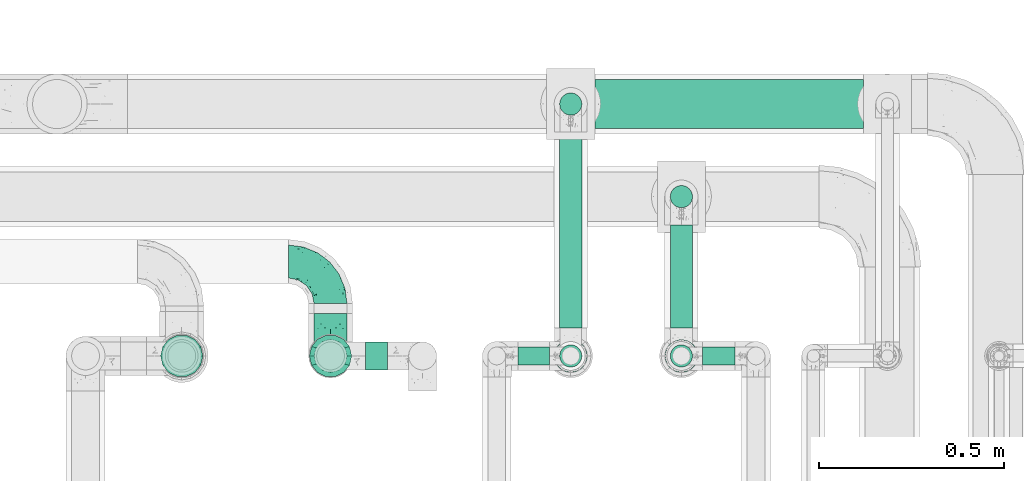
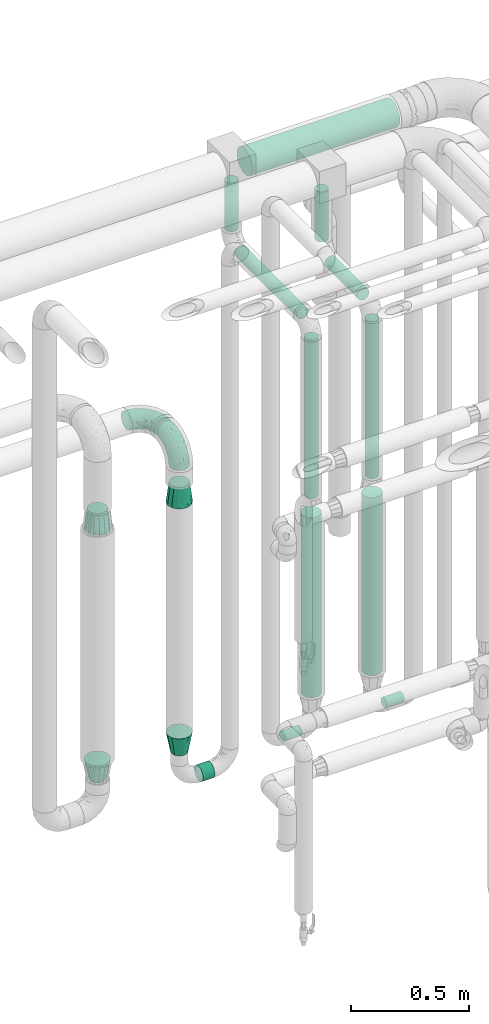
# One storey, part 712 of 827: 12 flow segments, 6 flow fittings.
"""IFC2X3 building model written with IfcOpenShell, lengths in millimetres."""

from ifc_helpers import new_model, entity, si_unit, converted_unit, derived_unit, direction, frame, origin, origin_2d_with_axis, place, context, subcontext, project, spatial, circle, extrude, faceted_brep, source, transform, mapped, material, type_object, type_shapes, element, save


model = new_model("IFC2X3")

# Units and contexts
model_context = context("Model", 3, precision=0.01, world=origin(), true_north=direction((6.12303176911189e-17, 1.0)))
body_context = subcontext(model_context, "Body", "Model", "MODEL_VIEW")
ifc_project = project(units=[si_unit("LENGTHUNIT", "METRE", prefix="MILLI"), si_unit("AREAUNIT", "SQUARE_METRE"), si_unit("VOLUMEUNIT", "CUBIC_METRE"), converted_unit("PLANEANGLEUNIT", "DEGREE", entity("IfcRatioMeasure", 0.0174532925199433), si_unit("PLANEANGLEUNIT", "RADIAN"), dimensions=[0, 0, 0, 0, 0, 0, 0]), si_unit("MASSUNIT", "GRAM", prefix="KILO"), derived_unit("MASSDENSITYUNIT", [(si_unit("MASSUNIT", "GRAM", prefix="KILO"), 1), (si_unit("LENGTHUNIT", "METRE"), -3)]), derived_unit("MOMENTOFINERTIAUNIT", [(si_unit("LENGTHUNIT", "METRE"), 4)]), si_unit("TIMEUNIT", "SECOND"), si_unit("FREQUENCYUNIT", "HERTZ"), si_unit("THERMODYNAMICTEMPERATUREUNIT", "DEGREE_CELSIUS"), derived_unit("THERMALTRANSMITTANCEUNIT", [(si_unit("MASSUNIT", "GRAM", prefix="KILO"), 1), (si_unit("THERMODYNAMICTEMPERATUREUNIT", "KELVIN"), -1), (si_unit("TIMEUNIT", "SECOND"), -3)]), derived_unit("VOLUMETRICFLOWRATEUNIT", [(si_unit("LENGTHUNIT", "METRE"), 3), (si_unit("TIMEUNIT", "SECOND"), -1)]), derived_unit("MASSFLOWRATEUNIT", [(si_unit("MASSUNIT", "GRAM", prefix="KILO"), 1), (si_unit("TIMEUNIT", "SECOND"), -1)]), derived_unit("ROTATIONALFREQUENCYUNIT", [(si_unit("TIMEUNIT", "SECOND"), -1)]), si_unit("ELECTRICCURRENTUNIT", "AMPERE"), si_unit("ELECTRICVOLTAGEUNIT", "VOLT"), si_unit("POWERUNIT", "WATT"), si_unit("FORCEUNIT", "NEWTON", prefix="KILO"), si_unit("ILLUMINANCEUNIT", "LUX"), si_unit("LUMINOUSFLUXUNIT", "LUMEN"), si_unit("LUMINOUSINTENSITYUNIT", "CANDELA"), derived_unit("USERDEFINED", [(si_unit("MASSUNIT", "GRAM", prefix="KILO"), -1), (si_unit("LENGTHUNIT", "METRE"), -2), (si_unit("TIMEUNIT", "SECOND"), 3), (si_unit("LUMINOUSFLUXUNIT", "LUMEN"), 1)]), derived_unit("LINEARVELOCITYUNIT", [(si_unit("LENGTHUNIT", "METRE"), 1), (si_unit("TIMEUNIT", "SECOND"), -1)]), si_unit("PRESSUREUNIT", "PASCAL"), derived_unit("USERDEFINED", [(si_unit("LENGTHUNIT", "METRE"), -2), (si_unit("MASSUNIT", "GRAM", prefix="KILO"), 1), (si_unit("TIMEUNIT", "SECOND"), -2)]), derived_unit("LINEARFORCEUNIT", [(si_unit("MASSUNIT", "GRAM", prefix="KILO"), 1), (si_unit("LENGTHUNIT", "METRE"), 1), (si_unit("TIMEUNIT", "SECOND"), -2), (si_unit("LENGTHUNIT", "METRE"), -1)]), derived_unit("PLANARFORCEUNIT", [(si_unit("MASSUNIT", "GRAM", prefix="KILO"), 1), (si_unit("LENGTHUNIT", "METRE"), 1), (si_unit("TIMEUNIT", "SECOND"), -2), (si_unit("LENGTHUNIT", "METRE"), -2)])], contexts=[model_context])

# Site, building, storey
site_placement = place(None, origin())
site = spatial("IfcSite", under=ifc_project, at=site_placement, CompositionType="ELEMENT")
building_placement = place(site_placement, origin())
building = spatial("IfcBuilding", under=site, at=building_placement, CompositionType="ELEMENT")
storey_placement = place(building_placement, frame((0.0, 0.0, 28200.0)))
storey = spatial("IfcBuildingStorey", under=building, at=storey_placement, Name="08", CompositionType="ELEMENT", Elevation=28200.0)

# Flow segments
pipe_segment_type_1 = type_object("IfcPipeSegmentType", PredefinedType="NOTDEFINED")
flow_segment_1_placement = place(storey_placement, frame((59362.89, 18112.0, 2831.9)))
element("IfcFlowSegment", 1, at=flow_segment_1_placement, inside=storey, type_object=pipe_segment_type_1, context=body_context, shape_type="SweptSolid", body=[
    extrude(circle(Radius=66.5, at=origin_2d_with_axis()), frame((0.0, 68.1, 68.1), z_axis=(1.0, 0.0, 0.0), x_axis=(0.0, 1.0, 0.0)), (0.0, 0.0, 1.0), 725.240640582081),
])
pipe_segment_type_2 = type_object("IfcPipeSegmentType", PredefinedType="NOTDEFINED")
flow_segment_2_placement = place(storey_placement, frame((59266.3, 18148.5, 2577.24)))
element("IfcFlowSegment", 2, at=flow_segment_2_placement, inside=storey, type_object=pipe_segment_type_2, context=body_context, shape_type="SweptSolid", body=[
    extrude(circle(Radius=30.0, at=origin_2d_with_axis()), frame((31.6, 31.6, 0.0)), (0.0, 0.0, 1.0), 252.756811194297),
])
flow_segment_3_placement = place(storey_placement, frame((59266.3, 17575.0, 2470.65)))
element("IfcFlowSegment", 3, at=flow_segment_3_placement, inside=storey, type_object=pipe_segment_type_2, context=body_context, shape_type="SweptSolid", body=[
    extrude(circle(Radius=30.0, at=origin_2d_with_axis()), frame((31.6, 0.0, 31.6), z_axis=(0.0, 1.0, 0.0), x_axis=(-1.0, 0.0, 0.0)), (0.0, 0.0, 1.0), 530.096114108994),
])
flow_segment_4_placement = place(storey_placement, frame((59266.3, 17468.4, 1602.24)))
element("IfcFlowSegment", 4, at=flow_segment_4_placement, inside=storey, type_object=pipe_segment_type_2, context=body_context, shape_type="SweptSolid", body=[
    extrude(circle(Radius=30.0, at=origin_2d_with_axis()), frame((31.6, 31.6, 0.0)), (0.0, 0.0, 1.0), 825.000000000016),
])
flow_segment_5_placement = place(storey_placement, frame((59565.07, 17898.5, 2570.74)))
element("IfcFlowSegment", 5, at=flow_segment_5_placement, inside=storey, type_object=pipe_segment_type_2, context=body_context, shape_type="SweptSolid", body=[
    extrude(circle(Radius=30.0, at=origin_2d_with_axis()), frame((31.6, 31.6, 0.0)), (0.0, 0.0, 1.0), 259.256811194313),
])
flow_segment_6_placement = place(storey_placement, frame((59565.07, 17576.0, 2463.15)))
element("IfcFlowSegment", 6, at=flow_segment_6_placement, inside=storey, type_object=pipe_segment_type_2, context=body_context, shape_type="SweptSolid", body=[
    extrude(circle(Radius=30.0, at=origin_2d_with_axis()), frame((31.6, 0.0, 31.6), z_axis=(0.0, 1.0, 0.0), x_axis=(-1.0, 0.0, 0.0)), (0.0, 0.0, 1.0), 278.096097794324),
])
flow_segment_7_placement = place(storey_placement, frame((59565.07, 17468.4, 1602.24)))
element("IfcFlowSegment", 7, at=flow_segment_7_placement, inside=storey, type_object=pipe_segment_type_2, context=body_context, shape_type="SweptSolid", body=[
    extrude(circle(Radius=30.0, at=origin_2d_with_axis()), frame((31.6, 31.6, 0.0)), (0.0, 0.0, 1.0), 816.499999999996),
])
flow_segment_8_placement = place(storey_placement, frame((59155.13, 17474.4, 374.4)))
element("IfcFlowSegment", 8, at=flow_segment_8_placement, inside=storey, type_object=pipe_segment_type_2, context=body_context, shape_type="SweptSolid", body=[
    extrude(circle(Radius=24.0, at=origin_2d_with_axis()), frame((0.0, 25.6, 25.6), z_axis=(1.0, 0.0, 0.0), x_axis=(0.0, -1.0, 0.0)), (0.0, 0.0, 1.0), 86.0000000000064),
])
flow_segment_9_placement = place(storey_placement, frame((59653.67, 17474.4, 374.4)))
element("IfcFlowSegment", 9, at=flow_segment_9_placement, inside=storey, type_object=pipe_segment_type_2, context=body_context, shape_type="SweptSolid", body=[
    extrude(circle(Radius=24.0, at=origin_2d_with_axis()), frame((0.0, 25.6, 25.6), z_axis=(1.0, 0.0, 0.0), x_axis=(0.0, 1.0, 0.0)), (0.0, 0.0, 1.0), 87.4629414974364),
])
flow_segment_10_placement = place(storey_placement, frame((58744.38, 17460.65, 310.65)))
element("IfcFlowSegment", 10, at=flow_segment_10_placement, inside=storey, type_object=pipe_segment_type_2, context=body_context, shape_type="SweptSolid", body=[
    extrude(circle(Radius=37.75, at=origin_2d_with_axis()), frame((0.0, 39.35, 39.35), z_axis=(1.0, 0.0, 0.0), x_axis=(0.0, 1.0, 0.0)), (0.0, 0.0, 1.0), 58.5322202972613),
])
flow_segment_11_placement = place(storey_placement, frame((59550.82, 17454.15, 589.0)))
element("IfcFlowSegment", 11, at=flow_segment_11_placement, inside=storey, type_object=pipe_segment_type_2, context=body_context, shape_type="SweptSolid", body=[
    extrude(circle(Radius=44.25, at=origin_2d_with_axis()), frame((45.85, 45.85, 0.0)), (0.0, 0.0, 1.0), 924.243188805704),
])
flow_segment_12_placement = place(storey_placement, frame((59252.05, 17454.15, 579.0)))
element("IfcFlowSegment", 12, at=flow_segment_12_placement, inside=storey, type_object=pipe_segment_type_2, context=body_context, shape_type="SweptSolid", body=[
    extrude(circle(Radius=44.25, at=origin_2d_with_axis()), frame((45.85, 45.85, 0.0)), (0.0, 0.0, 1.0), 934.243188805697),
])

# Flow fittings
ifc_material = material()
pipe_fitting_type_1 = type_object("IfcPipeFittingType", Name="ADSK_1", PredefinedType="NOTDEFINED", material=ifc_material)
shared_shape_1 = source(origin(), body_context, "Body", "Brep", [
    faceted_brep([(-114.0, 22.22, -38.49), (-114.0, 11.5, -42.94), (-114.0, 0.0, -44.45), (-114.0, -11.5, -42.94), (-114.0, -22.23, -38.49), (-114.0, -31.43, -31.43), (-114.0, -38.49, -22.23), (-114.0, -42.94, -11.5), (-114.0, -44.45, 0.0), (-114.0, -42.94, 11.5), (-114.0, -38.49, 22.22), (-114.0, -31.43, 31.43), (-114.0, -22.23, 38.49), (-114.0, -11.5, 42.94), (-114.0, 0.0, 44.45), (-114.0, 11.5, 42.94), (-114.0, 22.22, 38.49), (-114.0, 31.43, 31.43), (-114.0, 38.49, 22.22), (-114.0, 42.94, 11.5), (-114.0, 44.45, 0.0), (-114.0, 42.94, -11.5), (-114.0, 38.49, -22.23), (-114.0, 31.43, -31.43), (0.0, 114.0, -44.45), (-11.5, 114.0, -42.94), (-22.22, 114.0, -38.49), (-31.43, 114.0, -31.43), (-38.49, 114.0, -22.23), (-42.94, 114.0, -11.5), (-44.45, 114.0, 0.0), (-42.94, 114.0, 11.5), (-38.49, 114.0, 22.22), (-31.43, 114.0, 31.43), (-22.22, 114.0, 38.49), (-11.5, 114.0, 42.94), (0.0, 114.0, 44.45), (11.5, 114.0, 42.94), (22.23, 114.0, 38.49), (31.43, 114.0, 31.43), (38.49, 114.0, 22.22), (42.94, 114.0, 11.5), (44.45, 114.0, 0.0), (42.94, 114.0, -11.5), (38.49, 114.0, -22.23), (31.43, 114.0, -31.43), (22.23, 114.0, -38.49), (11.5, 114.0, -42.94), (-24.5, -15.82, 8.24), (-7.18, -2.06, 7.97), (-13.53, -4.79, 15.72), (-92.03, -41.56, 0.0), (-77.08, -37.56, 14.57), (23.74, 74.96, 33.55), (-72.99, -39.05, 0.0), (-84.56, -15.6, 40.23), (-47.88, -6.37, 37.83), (-59.8, 2.77, 43.37), (-84.46, -33.54, 25.41), (16.69, 49.28, 31.02), (6.37, 47.88, 37.83), (3.35, 25.47, 29.77), (-47.43, 81.55, 19.51), (-74.96, -23.74, 33.55), (-46.77, -27.89, 11.23), (-53.88, -31.14, 0.0), (-87.05, 38.52, 28.81), (-63.44, 55.78, 24.79), (-93.24, 43.37, 18.58), (-16.67, 16.67, 37.64), (-25.47, -3.35, 29.77), (-17.2, 97.7, 41.53), (-7.42, 85.54, 44.3), (-67.09, 46.29, 31.23), (-18.08, 42.1, 44.06), (-32.93, 14.9, 42.17), (-11.54, 34.94, 41.69), (-95.7, 27.79, 36.14), (-88.55, -4.92, 43.79), (-2.77, 59.8, 43.37), (-87.65, 48.44, 9.87), (-81.01, 8.37, 44.32), (-37.63, 90.26, 28.6), (-51.29, 61.56, 30.59), (-29.32, 87.72, 36.52), (23.49, 49.5, 23.28), (8.19, 20.11, 19.18), (-70.06, 58.9, 9.01), (-87.38, 49.74, 0.0), (-88.15, 18.57, 41.8), (-7.96, 6.22, 24.33), (33.54, 84.46, 25.41), (37.56, 77.08, 14.57), (-58.37, 34.98, 40.92), (-62.38, 23.02, 43.45), (24.15, 39.93, 12.16), (31.14, 53.88, 0.0), (-58.13, 14.61, 44.45), (-37.17, 26.09, 44.37), (4.92, 88.55, 43.79), (-34.77, -23.22, 0.0), (-49.5, -23.49, 23.28), (41.56, 92.03, 0.0), (-57.83, 66.03, 19.12), (-71.84, 54.46, 17.06), (-46.46, 94.23, 8.51), (-49.74, 87.38, 0.0), (-38.96, 59.98, 38.88), (-55.29, 46.95, 36.83), (-64.82, 64.82, 0.0), (-55.88, 73.75, 10.01), (15.6, 84.56, 40.23), (-21.6, 76.38, 42.11), (-49.04, -15.53, 31.95), (-19.97, 55.59, 44.33), (-73.61, 33.95, 37.2), (-31.05, 58.14, 42.19), (-41.3, 41.3, 43.02), (-27.36, -11.22, 22.61), (9.28, 15.84, 8.73), (23.22, 34.77, 0.0), (39.05, 72.99, 0.0), (-1.96, 1.96, 0.0), (10.63, 18.37, 0.0), (-18.37, -10.63, 0.0), (-97.7, 17.2, -41.53), (9.28, 15.84, -8.73), (-13.53, -4.79, -15.72), (8.19, 20.11, -19.18), (-85.54, 7.42, -44.3), (-8.37, 81.01, -44.32), (-90.26, 37.63, -28.6), (-87.72, 29.32, -36.52), (-27.79, 95.7, -36.14), (-38.52, 87.05, -28.81), (-94.23, 46.46, -8.51), (-84.56, -15.6, -40.23), (-73.75, 55.88, -10.01), (-10.19, -4.86, -7.51), (-76.38, 21.6, -42.11), (-59.98, 38.96, -38.88), (-49.28, -16.69, -31.02), (-47.88, -6.37, -37.83), (-25.47, -3.35, -29.77), (-34.98, 58.37, -40.92), (-46.95, 55.29, -36.83), (-77.08, -37.56, -14.57), (-18.57, 88.15, -41.8), (-23.02, 62.38, -43.45), (-55.78, 63.44, -24.79), (-43.37, 93.24, -18.58), (-84.46, -33.54, -25.41), (-33.95, 73.61, -37.2), (-46.29, 67.09, -31.23), (-74.96, -23.74, -33.55), (-48.44, 87.65, -9.87), (-45.44, -27.06, -11.87), (-88.55, -4.92, -43.79), (-49.5, -23.49, -23.28), (-14.61, 58.13, -44.45), (-26.09, 37.17, -44.37), (15.6, 84.56, -40.23), (6.37, 47.88, -37.83), (-2.77, 59.8, -43.37), (-81.55, 47.43, -19.51), (33.54, 84.46, -25.41), (23.49, 49.5, -23.28), (23.74, 74.96, -33.55), (-42.1, 18.08, -44.06), (-14.9, 32.93, -42.17), (-34.94, 11.54, -41.69), (-61.56, 51.29, -30.59), (-27.36, -11.22, -22.61), (37.56, 77.08, -14.57), (4.92, 88.55, -43.79), (-59.8, 2.77, -43.37), (-66.03, 57.83, -19.12), (-54.46, 71.84, -17.06), (-55.59, 19.97, -44.33), (-58.9, 70.06, -9.01), (24.15, 39.93, -12.16), (15.53, 49.04, -31.95), (-58.14, 31.05, -42.19), (-41.3, 41.3, -43.02), (-16.67, 16.67, -37.64), (3.35, 25.47, -29.77), (-7.96, 6.22, -24.33), (-26.36, -16.33, -11.05)], [[[0, 1, 2, 3, 4, 5, 6, 7, 8, 9, 10, 11, 12, 13, 14, 15, 16, 17, 18, 19, 20, 21, 22, 23]], [[24, 25, 26, 27, 28, 29, 30, 31, 32, 33, 34, 35, 36, 37, 38, 39, 40, 41, 42, 43, 44, 45, 46, 47]], [[48, 49, 50]], [[51, 52, 9]], [[53, 39, 38]], [[9, 52, 10]], [[54, 52, 51]], [[55, 56, 57]], [[11, 10, 58]], [[59, 60, 61]], [[32, 31, 62]], [[63, 12, 11]], [[63, 55, 12]], [[64, 52, 65]], [[66, 67, 68]], [[69, 56, 70]], [[35, 71, 72]], [[67, 66, 73]], [[74, 75, 76]], [[16, 77, 17]], [[13, 78, 14]], [[76, 79, 74]], [[68, 80, 19]], [[18, 17, 66]], [[14, 78, 81]], [[20, 19, 80]], [[82, 83, 84]], [[85, 61, 86]], [[87, 88, 80]], [[18, 68, 19]], [[15, 89, 16]], [[14, 81, 15]], [[70, 90, 61]], [[17, 77, 66]], [[91, 85, 92]], [[93, 89, 94]], [[95, 96, 92]], [[84, 71, 34]], [[94, 97, 98]], [[37, 36, 99]], [[40, 39, 91]], [[40, 92, 41]], [[65, 100, 64]], [[91, 92, 40]], [[58, 101, 63]], [[92, 102, 41]], [[92, 85, 95]], [[67, 103, 104]], [[34, 33, 84]], [[105, 62, 31]], [[52, 58, 10]], [[106, 105, 30]], [[93, 107, 108]], [[106, 109, 110]], [[53, 111, 60]], [[84, 112, 71]], [[84, 107, 112]], [[33, 82, 84]], [[12, 55, 13]], [[113, 56, 63]], [[111, 38, 37]], [[34, 71, 35]], [[36, 35, 72]], [[112, 114, 72]], [[110, 105, 106]], [[111, 53, 38]], [[115, 108, 73]], [[89, 15, 81]], [[104, 87, 80]], [[110, 87, 103]], [[33, 32, 82]], [[116, 107, 117]], [[112, 116, 114]], [[99, 72, 79]], [[56, 55, 63]], [[78, 55, 57]], [[101, 118, 113]], [[56, 69, 75]], [[99, 111, 37]], [[79, 76, 60]], [[79, 60, 111]], [[60, 69, 61]], [[101, 58, 52]], [[63, 11, 58]], [[39, 53, 91]], [[85, 91, 53]], [[94, 89, 81]], [[77, 89, 115]], [[84, 83, 107]], [[93, 108, 115]], [[98, 114, 117]], [[79, 72, 114]], [[98, 117, 94]], [[98, 57, 75]], [[32, 62, 82]], [[83, 82, 62]], [[70, 113, 118]], [[61, 85, 59]], [[48, 64, 100]], [[95, 119, 120]], [[69, 70, 61]], [[70, 118, 90]], [[72, 99, 36]], [[111, 99, 79]], [[55, 78, 13]], [[81, 78, 57]], [[94, 81, 97]], [[93, 94, 117]], [[66, 68, 18]], [[80, 68, 104]], [[103, 87, 104]], [[80, 88, 20]], [[50, 49, 119]], [[95, 85, 86]], [[119, 95, 86]], [[121, 92, 96]], [[50, 119, 86]], [[119, 122, 123, 120]], [[110, 109, 87]], [[88, 87, 109]], [[62, 105, 110]], [[30, 105, 31]], [[81, 57, 97]], [[57, 98, 97]], [[107, 93, 117]], [[89, 93, 115]], [[107, 83, 108]], [[73, 108, 83]], [[67, 73, 83]], [[115, 73, 66]], [[103, 83, 62]], [[67, 104, 68]], [[83, 103, 67]], [[110, 103, 62]], [[89, 77, 16]], [[66, 77, 115]], [[56, 75, 57]], [[76, 75, 69]], [[60, 76, 69]], [[79, 114, 74]], [[114, 98, 74]], [[75, 74, 98]], [[9, 8, 51]], [[102, 92, 121]], [[102, 42, 41]], [[72, 71, 112]], [[52, 54, 65]], [[64, 48, 118]], [[101, 52, 64]], [[124, 122, 49]], [[118, 48, 50]], [[49, 48, 124]], [[119, 49, 122]], [[48, 100, 124]], [[114, 116, 117]], [[112, 107, 116]], [[101, 113, 63]], [[70, 56, 113]], [[64, 118, 101]], [[90, 50, 86]], [[50, 90, 118]], [[61, 90, 86]], [[85, 53, 59]], [[60, 59, 53]], [[95, 120, 96]], [[125, 1, 0]], [[126, 127, 128]], [[2, 1, 129]], [[24, 130, 25]], [[131, 132, 23]], [[27, 133, 134]], [[88, 135, 20]], [[136, 4, 3]], [[88, 109, 137]], [[138, 122, 124]], [[139, 132, 140]], [[141, 142, 143]], [[144, 140, 145]], [[125, 132, 139]], [[6, 146, 7]], [[144, 147, 148]], [[146, 51, 7]], [[134, 149, 150]], [[146, 6, 151]], [[152, 145, 153]], [[154, 4, 136]], [[154, 136, 142]], [[150, 155, 29]], [[43, 42, 102]], [[65, 146, 156]], [[0, 23, 132]], [[157, 3, 2]], [[146, 151, 158]], [[148, 159, 160]], [[161, 162, 163]], [[135, 164, 21]], [[165, 166, 167]], [[168, 169, 170]], [[147, 25, 130]], [[171, 132, 131]], [[155, 30, 29]], [[172, 141, 143]], [[134, 28, 27]], [[149, 134, 153]], [[173, 165, 44]], [[26, 25, 147]], [[22, 21, 164]], [[24, 174, 130]], [[133, 27, 26]], [[170, 175, 168]], [[24, 47, 174]], [[45, 167, 46]], [[28, 150, 29]], [[1, 125, 129]], [[156, 100, 65]], [[165, 45, 44]], [[161, 46, 167]], [[173, 44, 43]], [[6, 5, 151]], [[173, 102, 121]], [[137, 135, 88]], [[46, 161, 47]], [[102, 173, 43]], [[149, 176, 177]], [[172, 158, 141]], [[139, 178, 129]], [[154, 5, 4]], [[156, 146, 158]], [[106, 155, 179]], [[173, 96, 180]], [[181, 162, 167]], [[177, 179, 155]], [[137, 179, 176]], [[23, 22, 131]], [[182, 140, 183]], [[139, 182, 178]], [[157, 129, 175]], [[157, 136, 3]], [[175, 170, 142]], [[175, 142, 136]], [[142, 184, 143]], [[162, 161, 167]], [[174, 161, 163]], [[181, 166, 185]], [[162, 184, 169]], [[5, 154, 151]], [[158, 151, 154]], [[166, 165, 173]], [[167, 45, 165]], [[148, 147, 130]], [[133, 147, 152]], [[132, 171, 140]], [[144, 145, 152]], [[160, 178, 183]], [[175, 129, 178]], [[160, 183, 148]], [[160, 163, 169]], [[22, 164, 131]], [[171, 131, 164]], [[162, 185, 184]], [[186, 127, 172]], [[185, 128, 186]], [[156, 187, 100]], [[185, 166, 128]], [[143, 184, 185]], [[129, 157, 2]], [[136, 157, 175]], [[161, 174, 47]], [[130, 174, 163]], [[148, 130, 159]], [[144, 148, 183]], [[134, 150, 28]], [[155, 150, 177]], [[176, 179, 177]], [[155, 106, 30]], [[166, 180, 128]], [[128, 180, 126]], [[173, 180, 166]], [[126, 120, 123, 122]], [[120, 126, 180]], [[122, 138, 126]], [[137, 109, 179]], [[106, 179, 109]], [[164, 135, 137]], [[20, 135, 21]], [[130, 163, 159]], [[163, 160, 159]], [[140, 144, 183]], [[147, 144, 152]], [[140, 171, 145]], [[153, 145, 171]], [[149, 153, 171]], [[152, 153, 134]], [[176, 171, 164]], [[149, 177, 150]], [[171, 176, 149]], [[137, 176, 164]], [[147, 133, 26]], [[134, 133, 152]], [[162, 169, 163]], [[170, 169, 184]], [[142, 170, 184]], [[175, 178, 168]], [[178, 160, 168]], [[169, 168, 160]], [[51, 146, 54]], [[51, 8, 7]], [[132, 125, 0]], [[129, 125, 139]], [[156, 158, 172]], [[65, 54, 146]], [[178, 182, 183]], [[139, 140, 182]], [[158, 154, 141]], [[142, 141, 154]], [[186, 172, 143]], [[172, 127, 187]], [[185, 186, 143]], [[127, 186, 128]], [[187, 127, 138]], [[124, 100, 187]], [[126, 138, 127]], [[187, 138, 124]], [[172, 187, 156]], [[166, 181, 167]], [[185, 162, 181]], [[96, 173, 121]], [[96, 120, 180]]]),
])
type_shapes(pipe_fitting_type_1, [shared_shape_1])
for number, where, z_axis, x_axis, name in (
    (13, (58649.38, 17755.1, 2100.0), (0.0, 0.0, 1.0), (0.0, 1.0, 0.0), "ADSK_1"),
    (14, (58649.38, 17500.0, 2100.0), (1.0, 0.0, 0.0), (0.0, -1.0, 0.0), "ADSK_1"),
):
    element("IfcFlowFitting", number, at=place(storey_placement, frame(where, z_axis=z_axis, x_axis=x_axis)), inside=storey, type_object=pipe_fitting_type_1, material=ifc_material, Name=name, ObjectType="ADSK_1", context=body_context, shape_type="MappedRepresentation", body=[
        mapped(shared_shape_1, transform((0.0, 0.0, 0.0), scale=1.0)),
    ])
pipe_fitting_type_2 = type_object("IfcPipeFittingType", Name="ADSK_1", PredefinedType="NOTDEFINED", material=ifc_material)
shared_shape_2 = source(origin(), body_context, "Body", "Brep", [
    faceted_brep([(102.0, -57.15, 0.0), (102.0, -54.32, -12.4), (102.0, -51.49, -24.8), (102.0, -43.56, -34.74), (102.0, -35.63, -44.68), (102.0, -24.17, -50.2), (102.0, -12.72, -55.72), (102.0, 0.0, -55.72), (102.0, 12.72, -55.72), (102.0, 24.17, -50.2), (102.0, 35.63, -44.68), (102.0, 43.56, -34.74), (102.0, 51.49, -24.8), (102.0, 54.32, -12.4), (102.0, 57.15, 0.0), (102.0, 54.32, 12.4), (102.0, 51.49, 24.8), (102.0, 43.56, 34.74), (102.0, 35.63, 44.68), (102.0, 24.17, 50.2), (102.0, 12.72, 55.72), (102.0, 0.0, 55.72), (102.0, -12.72, 55.72), (102.0, -24.17, 50.2), (102.0, -35.63, 44.68), (102.0, -43.56, 34.74), (102.0, -51.49, 24.8), (102.0, -54.32, 12.4), (0.0, -38.49, -22.22), (0.0, -41.47, -11.11), (0.0, -44.45, 0.0), (0.0, -41.47, 11.11), (0.0, -38.49, 22.23), (0.0, -30.36, 30.36), (0.0, -22.23, 38.49), (0.0, -11.11, 41.47), (0.0, 0.0, 44.45), (0.0, 11.11, 41.47), (0.0, 22.23, 38.49), (0.0, 30.36, 30.36), (0.0, 38.49, 22.23), (0.0, 41.47, 11.11), (0.0, 44.45, 0.0), (0.0, 41.47, -11.11), (0.0, 38.49, -22.23), (0.0, 30.36, -30.36), (0.0, 22.22, -38.49), (0.0, 11.11, -41.47), (0.0, 0.0, -44.45), (0.0, -11.11, -41.47), (0.0, -22.23, -38.49), (0.0, -30.36, -30.36)], [[[0, 1, 2, 3, 4, 5, 6, 7, 8, 9, 10, 11, 12, 13, 14, 15, 16, 17, 18, 19, 20, 21, 22, 23, 24, 25, 26, 27]], [[28, 29, 30, 31, 32, 33, 34, 35, 36, 37, 38, 39, 40, 41, 42, 43, 44, 45, 46, 47, 48, 49, 50, 51]], [[28, 2, 29]], [[11, 10, 45]], [[11, 44, 12]], [[3, 2, 28]], [[30, 29, 1]], [[42, 13, 43]], [[30, 1, 0]], [[46, 10, 9]], [[48, 8, 7, 6]], [[28, 51, 3]], [[29, 2, 1]], [[47, 46, 9]], [[5, 4, 50]], [[51, 4, 3]], [[8, 48, 47]], [[13, 42, 14]], [[51, 50, 4]], [[8, 47, 9]], [[5, 49, 6]], [[44, 11, 45]], [[43, 12, 44]], [[10, 46, 45]], [[49, 5, 50]], [[49, 48, 6]], [[13, 12, 43]], [[40, 16, 41]], [[25, 24, 33]], [[25, 32, 26]], [[17, 16, 40]], [[42, 41, 15]], [[30, 27, 31]], [[42, 15, 14]], [[34, 24, 23]], [[36, 22, 21, 20]], [[40, 39, 17]], [[41, 16, 15]], [[35, 34, 23]], [[19, 18, 38]], [[39, 18, 17]], [[22, 36, 35]], [[27, 30, 0]], [[39, 38, 18]], [[22, 35, 23]], [[19, 37, 20]], [[32, 25, 33]], [[31, 26, 32]], [[24, 34, 33]], [[37, 19, 38]], [[37, 36, 20]], [[27, 26, 31]]]),
])
type_shapes(pipe_fitting_type_2, [shared_shape_2])
for number, where, z_axis, x_axis, name in (
    (15, (58247.57, 17500.0, 1902.45), (0.0, 1.0, 0.0), (0.0, 0.0, -1.0), "ADSK_1"),
    (16, (58649.38, 17500.0, 1898.17), (0.0, -1.0, 0.0), (0.0, 0.0, -1.0), "ADSK_1"),
):
    element("IfcFlowFitting", number, at=place(storey_placement, frame(where, z_axis=z_axis, x_axis=x_axis)), inside=storey, type_object=pipe_fitting_type_2, material=ifc_material, Name=name, ObjectType="ADSK_1", context=body_context, shape_type="MappedRepresentation", body=[
        mapped(shared_shape_2, transform((0.0, 0.0, 0.0), scale=1.0)),
    ])
pipe_fitting_type_3 = type_object("IfcPipeFittingType", Name="ADSK_1", PredefinedType="NOTDEFINED", material=ifc_material)
shared_shape_3 = source(origin(), body_context, "Body", "Brep", [
    faceted_brep([(102.0, 38.05, 0.0), (102.0, 35.5, 9.51), (102.0, 32.95, 19.03), (102.0, 25.99, 25.99), (102.0, 19.02, 32.95), (102.0, 9.51, 35.5), (102.0, 0.0, 38.05), (102.0, -9.51, 35.5), (102.0, -19.03, 32.95), (102.0, -25.99, 25.99), (102.0, -32.95, 19.03), (102.0, -35.5, 9.51), (102.0, -38.05, 0.0), (102.0, -35.5, -9.51), (102.0, -32.95, -19.02), (102.0, -25.99, -25.99), (102.0, -19.03, -32.95), (102.0, -9.51, -35.5), (102.0, 0.0, -38.05), (102.0, 9.51, -35.5), (102.0, 19.02, -32.95), (102.0, 25.99, -25.99), (102.0, 32.95, -19.02), (102.0, 35.5, -9.51), (0.0, 43.56, 34.74), (0.0, 51.49, 24.8), (0.0, 54.32, 12.4), (0.0, 57.15, 0.0), (0.0, 54.32, -12.4), (0.0, 51.49, -24.8), (0.0, 43.56, -34.74), (0.0, 35.63, -44.68), (0.0, 24.17, -50.2), (0.0, 12.72, -55.72), (0.0, 0.0, -55.72), (0.0, -12.72, -55.72), (0.0, -24.17, -50.2), (0.0, -35.63, -44.68), (0.0, -43.56, -34.74), (0.0, -51.49, -24.8), (0.0, -54.32, -12.4), (0.0, -57.15, 0.0), (0.0, -54.32, 12.4), (0.0, -51.49, 24.8), (0.0, -43.56, 34.74), (0.0, -35.63, 44.68), (0.0, -24.17, 50.2), (0.0, -12.72, 55.72), (0.0, 0.0, 55.72), (0.0, 12.72, 55.72), (0.0, 24.17, 50.2), (0.0, 35.63, 44.68)], [[[0, 1, 2, 3, 4, 5, 6, 7, 8, 9, 10, 11, 12, 13, 14, 15, 16, 17, 18, 19, 20, 21, 22, 23]], [[24, 25, 26, 27, 28, 29, 30, 31, 32, 33, 34, 35, 36, 37, 38, 39, 40, 41, 42, 43, 44, 45, 46, 47, 48, 49, 50, 51]], [[32, 31, 20]], [[40, 12, 41]], [[30, 29, 22]], [[22, 29, 23]], [[40, 39, 13]], [[12, 40, 13]], [[37, 16, 15]], [[18, 35, 34, 33]], [[16, 37, 36]], [[32, 19, 33]], [[36, 17, 16]], [[22, 21, 30]], [[38, 14, 39]], [[23, 29, 28]], [[21, 31, 30]], [[0, 28, 27]], [[36, 35, 17]], [[0, 23, 28]], [[39, 14, 13]], [[14, 38, 15]], [[21, 20, 31]], [[19, 18, 33]], [[35, 18, 17]], [[38, 37, 15]], [[19, 32, 20]], [[46, 45, 8]], [[26, 0, 27]], [[44, 43, 10]], [[10, 43, 11]], [[26, 25, 1]], [[0, 26, 1]], [[51, 4, 3]], [[6, 49, 48, 47]], [[4, 51, 50]], [[46, 7, 47]], [[50, 5, 4]], [[10, 9, 44]], [[24, 2, 25]], [[11, 43, 42]], [[9, 45, 44]], [[12, 42, 41]], [[50, 49, 5]], [[12, 11, 42]], [[25, 2, 1]], [[2, 24, 3]], [[9, 8, 45]], [[7, 6, 47]], [[49, 6, 5]], [[24, 51, 3]], [[7, 46, 8]]]),
])
type_shapes(pipe_fitting_type_3, [shared_shape_3])
for number, where, z_axis, x_axis, name in (
    (17, (58247.57, 17500.0, 602.0), (0.0, 1.0, 0.0), (0.0, 0.0, -1.0), "ADSK_1"),
    (18, (58649.38, 17500.0, 602.0), (0.0, -1.0, 0.0), (0.0, 0.0, -1.0), "ADSK_1"),
):
    element("IfcFlowFitting", number, at=place(storey_placement, frame(where, z_axis=z_axis, x_axis=x_axis)), inside=storey, type_object=pipe_fitting_type_3, material=ifc_material, Name=name, ObjectType="ADSK_1", context=body_context, shape_type="MappedRepresentation", body=[
        mapped(shared_shape_3, transform((0.0, 0.0, 0.0), scale=1.0)),
    ])

save(model, "model.ifc")
